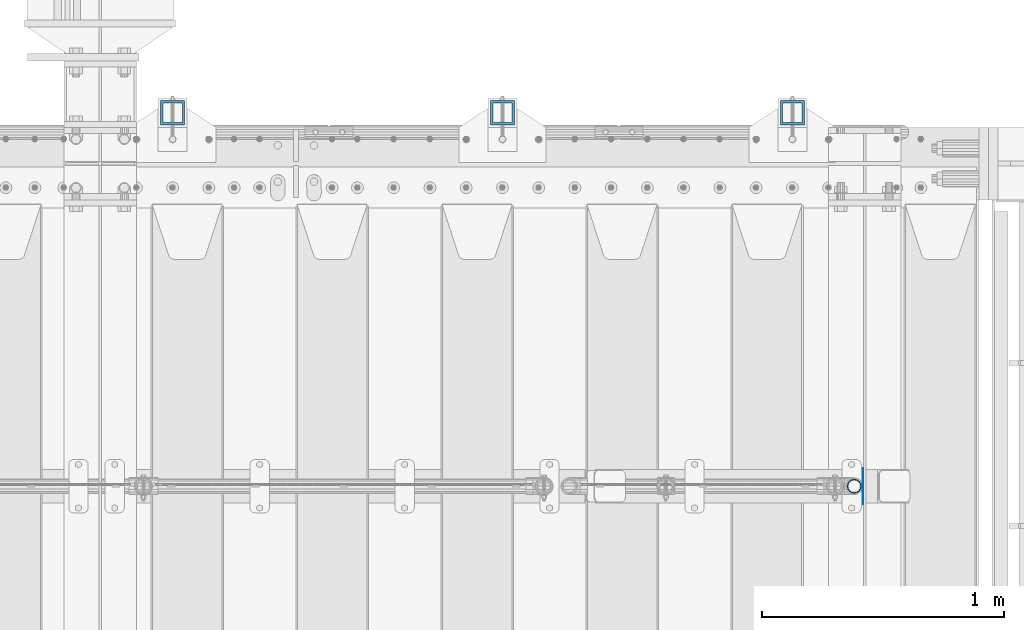
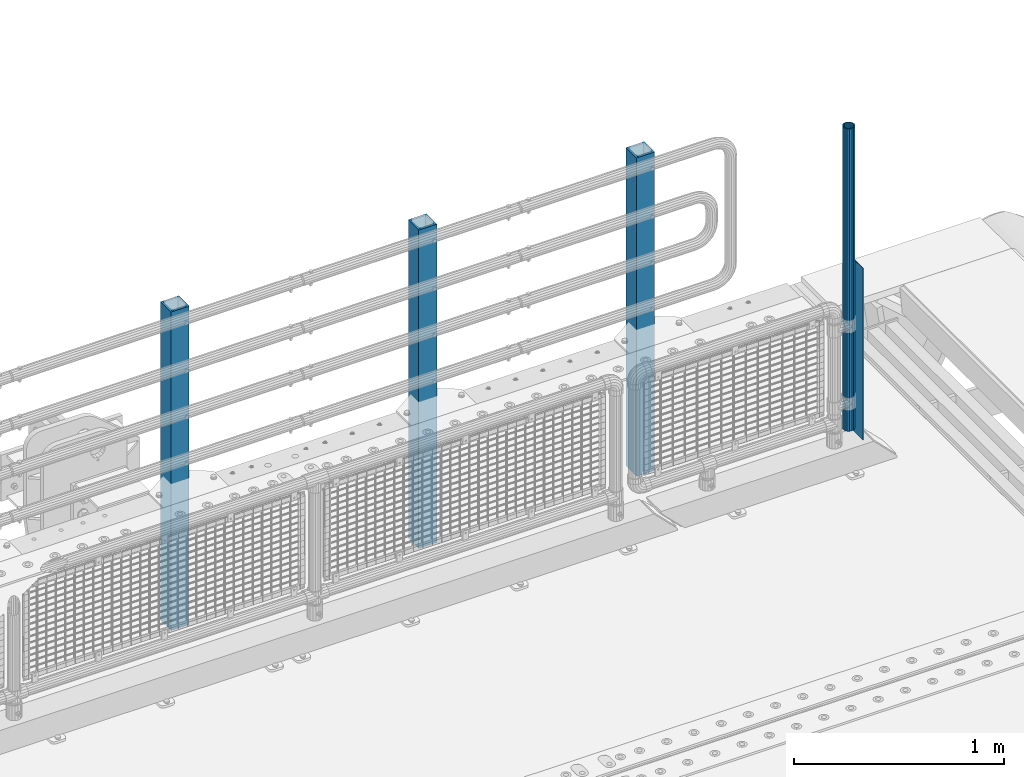
# One storey, part 61 of 219: 5 columns.
"""IFC2X3 building model written with IfcOpenShell, lengths in millimetres."""

from ifc_helpers import new_model, si_unit, frame, origin_with_axes, place, context, subcontext, project, spatial, faceted_brep, material, type_object, element, save


model = new_model("IFC2X3")

# Units and contexts
model_context = context("Model", 3, precision=1e-05, world=origin_with_axes())
body_context = subcontext(model_context, "Body", "Model", "MODEL_VIEW")
ifc_project = project(units=[si_unit("LENGTHUNIT", "METRE", prefix="MILLI"), si_unit("AREAUNIT", "SQUARE_METRE"), si_unit("VOLUMEUNIT", "CUBIC_METRE"), si_unit("MASSUNIT", "GRAM", prefix="KILO"), si_unit("TIMEUNIT", "SECOND"), si_unit("PLANEANGLEUNIT", "RADIAN"), si_unit("SOLIDANGLEUNIT", "STERADIAN"), si_unit("THERMODYNAMICTEMPERATUREUNIT", "DEGREE_CELSIUS"), si_unit("LUMINOUSINTENSITYUNIT", "LUMEN")], contexts=[model_context])

# Site, building, storey
site_placement = place(None, origin_with_axes())
site = spatial("IfcSite", under=ifc_project, at=site_placement, CompositionType="ELEMENT")
building_placement = place(site_placement, origin_with_axes())
building = spatial("IfcBuilding", under=site, at=building_placement, Name="Standard", CompositionType="ELEMENT")
storey_placement = place(building_placement, origin_with_axes())
storey = spatial("IfcBuildingStorey", under=building, at=storey_placement, Name="Undefined", CompositionType="ELEMENT", Elevation=0.0)

# Columns
ifc_material_1 = material(Name="Misc_Undefined")
column_type_1 = type_object("IfcColumnType", PredefinedType="NOTDEFINED")
column_1_placement = place(storey_placement, frame((13511.0, 31664.5, 238.02), z_axis=(-1.0, 0.0, 0.0), x_axis=(0.0, 0.0, 1.0)))
element("IfcColumn", 1, at=column_1_placement, inside=storey, type_object=column_type_1, material=ifc_material_1, context=body_context, shape_type="Brep", body=[
    faceted_brep([(0.0, -25.3499999999985, 0.0), (0.0, -23.4203461491597, 9.70102501045585), (1761.98, -23.4203461491597, 9.70102501045585), (1761.98, -25.3499999999985, 0.0), (0.0, -17.9251569030785, 17.9251569030785), (1761.98, -17.9251569030785, 17.9251569030785), (0.0, -9.70102501045403, 23.4203461491616), (1761.98, -9.70102501045403, 23.4203461491616), (0.0, 0.0, 25.3500000000004), (1761.98, 0.0, 25.3500000000004), (0.0, 9.70102501045403, 23.4203461491616), (1761.98, 9.70102501045403, 23.4203461491616), (0.0, 17.9251569030785, 17.9251569030785), (1761.98, 17.9251569030785, 17.9251569030785), (0.0, 23.4203461491597, 9.70102501045585), (1761.98, 23.4203461491597, 9.70102501045585), (0.0, 25.3499999999985, 0.0), (1761.98, 25.3499999999985, 0.0), (0.0, 23.4203461491597, -9.70102501045585), (1761.98, 23.4203461491597, -9.70102501045585), (0.0, 17.9251569030785, -17.9251569030785), (1761.98, 17.9251569030785, -17.9251569030785), (0.0, 9.70102501045403, -23.4203461491616), (1761.98, 9.70102501045403, -23.4203461491616), (0.0, 0.0, -25.3500000000004), (1761.98, 0.0, -25.3500000000004), (0.0, -9.70102501045403, -23.4203461491616), (1761.98, -9.70102501045403, -23.4203461491616), (0.0, -17.9251569030785, -17.9251569030785), (1761.98, -17.9251569030785, -17.9251569030785), (0.0, -23.4203461491597, -9.70102501045585), (1761.98, -23.4203461491597, -9.70102501045585), (0.0, -30.1500000000015, 0.0), (0.0, -27.8549679052157, -11.5379054858076), (1761.98, -27.8549679052157, -11.5379054858076), (1761.98, -30.1500000000015, 0.0), (0.0, -21.3192694527752, -21.3192694527752), (1761.98, -21.3192694527752, -21.3192694527752), (0.0, -11.5379054858058, -27.8549679052157), (1761.98, -11.5379054858058, -27.8549679052157), (0.0, 0.0, -30.1499999999996), (1761.98, 0.0, -30.1499999999996), (0.0, 11.5379054858058, -27.8549679052157), (1761.98, 11.5379054858058, -27.8549679052157), (0.0, 21.3192694527752, -21.3192694527752), (1761.98, 21.3192694527752, -21.3192694527752), (0.0, 27.8549679052157, -11.5379054858076), (1761.98, 27.8549679052157, -11.5379054858076), (0.0, 30.1500000000015, 0.0), (1761.98, 30.1500000000015, 0.0), (0.0, 27.8549679052157, 11.5379054858076), (1761.98, 27.8549679052157, 11.5379054858076), (0.0, 21.3192694527752, 21.3192694527752), (1761.98, 21.3192694527752, 21.3192694527752), (0.0, 11.5379054858058, 27.8549679052157), (1761.98, 11.5379054858058, 27.8549679052157), (0.0, 0.0, 30.1499999999996), (1761.98, 0.0, 30.1499999999996), (0.0, -11.5379054858058, 27.8549679052157), (1761.98, -11.5379054858058, 27.8549679052157), (0.0, -21.3192694527752, 21.3192694527752), (1761.98, -21.3192694527752, 21.3192694527752), (0.0, -27.8549679052157, 11.5379054858076), (1761.98, -27.8549679052157, 11.5379054858076)], [[[0, 1, 2, 3]], [[1, 4, 5, 2]], [[4, 6, 7, 5]], [[6, 8, 9, 7]], [[8, 10, 11, 9]], [[10, 12, 13, 11]], [[12, 14, 15, 13]], [[14, 16, 17, 15]], [[16, 18, 19, 17]], [[18, 20, 21, 19]], [[20, 22, 23, 21]], [[22, 24, 25, 23]], [[24, 26, 27, 25]], [[26, 28, 29, 27]], [[28, 30, 31, 29]], [[30, 0, 3, 31]], [[32, 33, 34, 35]], [[33, 36, 37, 34]], [[36, 38, 39, 37]], [[38, 40, 41, 39]], [[40, 42, 43, 41]], [[42, 44, 45, 43]], [[44, 46, 47, 45]], [[46, 48, 49, 47]], [[48, 50, 51, 49]], [[50, 52, 53, 51]], [[52, 54, 55, 53]], [[54, 56, 57, 55]], [[56, 58, 59, 57]], [[58, 60, 61, 59]], [[60, 62, 63, 61]], [[62, 32, 35, 63]], [[37, 39, 41, 43, 45, 47, 49, 51, 53, 55, 57, 59, 61, 63, 35, 34], [5, 7, 9, 11, 13, 15, 17, 19, 21, 23, 25, 27, 29, 31, 3, 2]], [[62, 60, 58, 56, 54, 52, 50, 48, 46, 44, 42, 40, 38, 36, 33, 32], [30, 28, 26, 24, 22, 20, 18, 16, 14, 12, 10, 8, 6, 4, 1, 0]]]),
])
column_type_2 = type_object("IfcColumnType", PredefinedType="NOTDEFINED")
column_2_placement = place(storey_placement, frame((13547.5, 31664.5, 200.0), z_axis=(0.0, 1.0, 0.0), x_axis=(0.0, 0.0, 1.0)))
element("IfcColumn", 2, at=column_2_placement, inside=storey, type_object=column_type_2, material=ifc_material_1, context=body_context, shape_type="Brep", body=[
    faceted_brep([(0.0, 1.5, -75.0), (0.0, 1.5, 75.0), (1000.0, 1.5, 75.0), (1000.0, 1.5, -75.0), (0.0, -1.5, 75.0), (1000.0, -1.5, 75.0), (0.0, -1.5, -75.0), (1000.0, -1.5, -75.0)], [[[0, 1, 2, 3]], [[1, 4, 5, 2]], [[4, 6, 7, 5]], [[6, 0, 3, 7]], [[5, 7, 3, 2]], [[6, 4, 1, 0]]]),
])
ifc_material_2 = material()
column_type_3 = type_object("IfcColumnType", PredefinedType="NOTDEFINED")
for number, where, z_axis, x_axis in (
    (3, (13255.0000000001, 33210.0000000002, -844.999999999998), (0.0, -1.0, 0.0), (0.0, 0.0, 1.0)),
    (4, (12055.0000000001, 33210.0000000002, -844.999999999998), (0.0, -1.0, 0.0), (0.0, 0.0, 1.0)),
    (5, (10690.0000000001, 33210.0000000002, -844.999999999998), (0.0, -1.0, 0.0), (0.0, 0.0, 1.0)),
):
    element("IfcColumn", number, at=place(storey_placement, frame(where, z_axis=z_axis, x_axis=x_axis)), inside=storey, type_object=column_type_3, material=ifc_material_2, context=body_context, shape_type="Brep", body=[
        faceted_brep([(0.0, 40.0, -40.0), (0.0, -40.0, -40.0), (1855.0, -40.0, -40.0), (1855.0, 40.0, -40.0), (0.0, -40.0, 40.0), (1855.0, -40.0, 40.0), (0.0, 40.0, 40.0), (1855.0, 40.0, 40.0), (0.0, 50.0, -50.0), (0.0, 50.0, 50.0), (1855.0, 50.0, 50.0), (1855.0, 50.0, -50.0), (0.0, -50.0, 50.0), (1855.0, -50.0, 50.0), (0.0, -50.0, -50.0), (1855.0, -50.0, -50.0)], [[[0, 1, 2, 3]], [[1, 4, 5, 2]], [[4, 6, 7, 5]], [[6, 0, 3, 7]], [[8, 9, 10, 11]], [[9, 12, 13, 10]], [[12, 14, 15, 13]], [[14, 8, 11, 15]], [[13, 15, 11, 10], [5, 7, 3, 2]], [[14, 12, 9, 8], [6, 4, 1, 0]]]),
    ])

save(model, "model.ifc")
